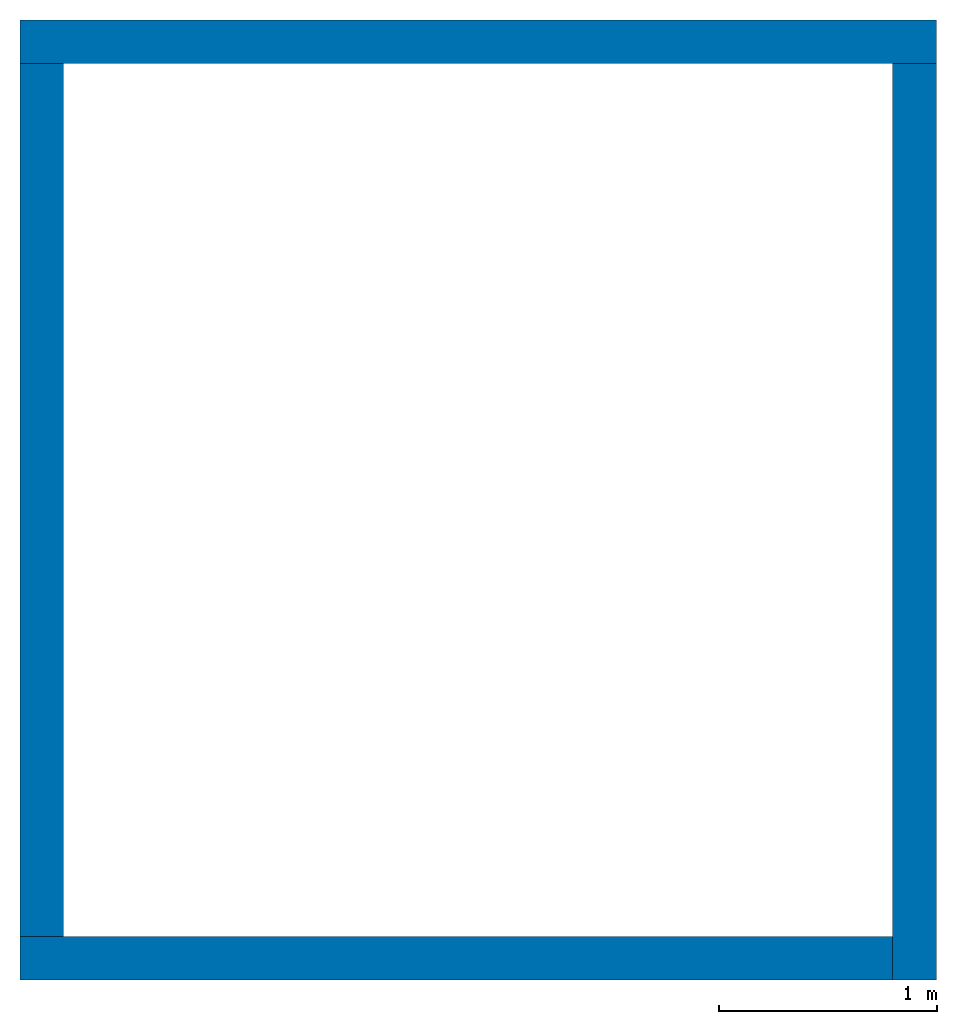
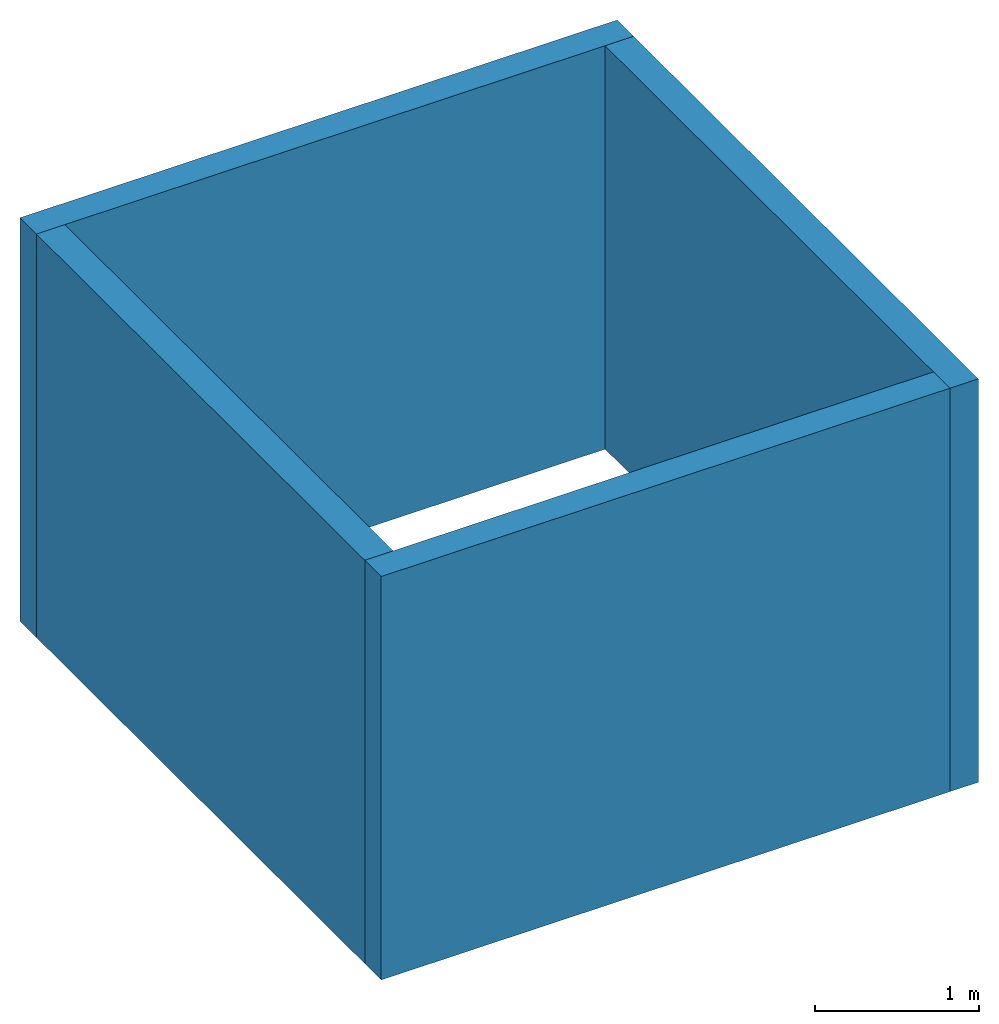
# Not in any storey: 4 walls.
"""IFC4 model written with IfcOpenShell, lengths in metres."""

from ifc_helpers import new_model, si_unit, frame, origin_with_axes, place, context, subcontext, project, polygons, element, save


model = new_model("IFC4")

# Units and contexts
model_context = context("Model", 3, precision=1e-05, world=origin_with_axes())
plan_context = context("Plan", 2, precision=1e-05, world=origin_with_axes())
body_context = subcontext(model_context, "Body", "Model", "MODEL_VIEW")
ifc_project = project(units=[si_unit("LENGTHUNIT", "METRE"), si_unit("AREAUNIT", "SQUARE_METRE"), si_unit("VOLUMEUNIT", "CUBIC_METRE")], contexts=[model_context, plan_context])

# Walls
wall_1_placement = place(None, origin_with_axes())
element("IfcWall", 1, at=wall_1_placement, Name="Wall_3", context=body_context, shape_type="Tessellation", body=[
    polygons([(0.0, 0.0, 0.0), (4.0, 0.0, 0.0), (0.0, 0.0, 3.0), (4.0, 0.0, 3.0), (0.0, -0.200000002980232, 0.0), (4.0, -0.200000002980232, 0.0), (0.0, -0.200000002980232, 3.0), (4.0, -0.200000002980232, 3.0)], [[[3, 4, 2, 1]], [[7, 5, 6, 8]], [[1, 2, 6, 5]], [[3, 1, 5, 7]], [[2, 4, 8, 6]], [[4, 3, 7, 8]]]),
])
wall_2_placement = place(None, frame((4.37113882867379e-08, 1.0, 0.0), z_axis=(0.0, 0.0, 1.0), x_axis=(-1.62920684942947e-07, -1.0, 0.0)))
element("IfcWall", 2, at=wall_2_placement, Name="Wall_4", context=body_context, shape_type="Tessellation", body=[
    polygons([(-3.0, -4.8876205482884e-07, 0.0), (1.0, 0.0, 0.0), (-3.0, -4.8876205482884e-07, 3.0), (1.0, 0.0, 3.0), (-3.0, 0.199999511241913, 0.0), (1.0, 0.200000002980232, 0.0), (-3.0, 0.199999511241913, 3.0), (1.0, 0.200000002980232, 3.0)], [[[4, 3, 1, 2]], [[8, 6, 5, 7]], [[2, 1, 5, 6]], [[1, 3, 7, 5]], [[4, 2, 6, 8]], [[3, 4, 8, 7]]]),
])
wall_3_placement = place(None, frame((4.0, -0.199999824166298, 0.0), z_axis=(0.0, 0.0, 1.0), x_axis=(1.94707183709397e-07, 1.0, 0.0)))
element("IfcWall", 3, at=wall_3_placement, Name="Wall_2", context=body_context, shape_type="Tessellation", body=[
    polygons([(0.0, 0.0, 0.0), (4.19999980926514, 6.23062931026652e-07, 0.0), (0.0, 0.0, 3.0), (4.19999980926514, 6.23062931026652e-07, 3.0), (0.0, -0.200000002980232, 0.0), (4.19999980926514, -0.199999377131462, 0.0), (0.0, -0.200000002980232, 3.0), (4.19999980926514, -0.199999377131462, 3.0)], [[[3, 4, 2, 1]], [[7, 5, 6, 8]], [[1, 2, 6, 5]], [[3, 1, 5, 7]], [[2, 4, 8, 6]], [[4, 3, 7, 8]]]),
])
wall_4_placement = place(None, frame((2.98023223876953e-08, 4.19999980926514, 0.0), z_axis=(0.0, 0.0, 1.0), x_axis=(1.0, 0.0, 0.0)))
element("IfcWall", 4, at=wall_4_placement, Name="Wall_1", context=body_context, shape_type="Tessellation", body=[
    polygons([(0.0, 0.0, 0.0), (4.19999980926514, 0.0, 0.0), (0.0, 0.0, 3.0), (4.19999980926514, 0.0, 3.0), (0.0, -0.200000002980232, 0.0), (4.19999980926514, -0.200000002980232, 0.0), (0.0, -0.200000002980232, 3.0), (4.19999980926514, -0.200000002980232, 3.0)], [[[3, 4, 2, 1]], [[7, 5, 6, 8]], [[1, 2, 6, 5]], [[3, 1, 5, 7]], [[2, 4, 8, 6]], [[4, 3, 7, 8]]]),
])

save(model, "model.ifc")
